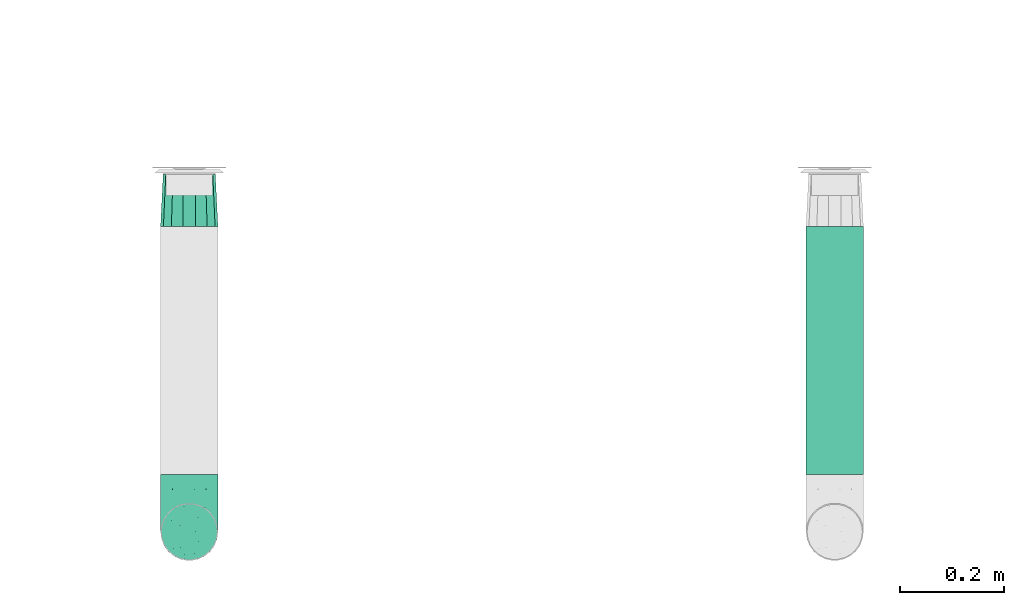
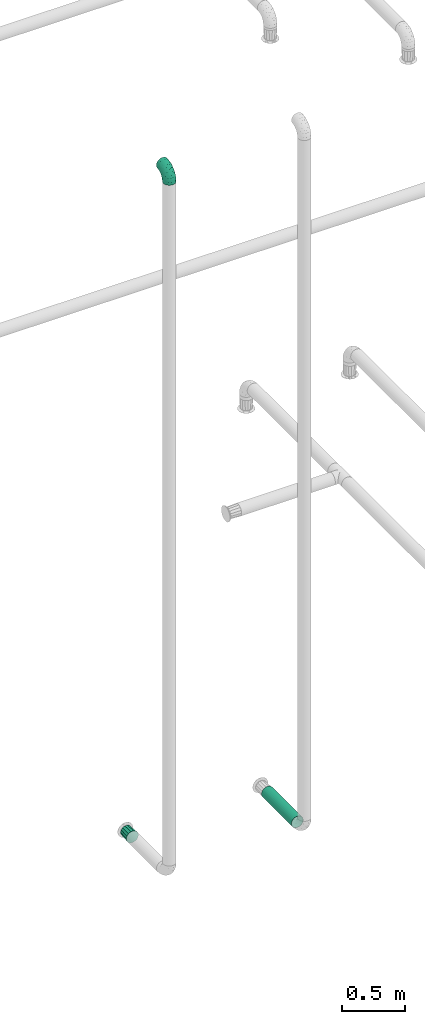
# One storey, part 34 of 123: 2 flow fittings, 1 flow segment.
"""IFC2X3 building model written with IfcOpenShell, lengths in millimetres."""

import ifcopenshell
import ifcopenshell.guid

model = None  # the IFC model being written
_history = None  # IfcOwnerHistory: only IFC2X3 demands one
_inside = {}  # id of a spatial element -> (the spatial element, [elements in it])
_under = {}  # id of a project, library or spatial element -> (it, [spatial elements below it])
_declared = {}  # id of a project -> (the project, [libraries it declares])
_typed = {}  # id of a type object -> (the type object, [elements of that type])
_made_of = {}  # id of a material, layer set ... -> (it, [elements and type objects made of it])


def new_model(schema):
    """Start an empty IFC model of exactly this schema.

    Asked for "IFC4X3", IfcOpenShell would pick the latest addendum, in which some entities
    have other attributes; the version numbers below select the first issue.
    IFC2X3 requires an IfcOwnerHistory on every rooted entity: one is made here for all.
    """
    global model, _history
    if schema == "IFC4X3":
        model = ifcopenshell.file(schema_version=(4, 3, 0, 0))
    else:
        model = ifcopenshell.file(schema=schema)
    _inside.clear()
    _under.clear()
    _declared.clear()
    _typed.clear()
    _made_of.clear()
    _history = None
    if model.schema == "IFC2X3":
        org = make("IfcOrganization", Name="unknown")
        user = make(
            "IfcPersonAndOrganization",
            ThePerson=make("IfcPerson", FamilyName="unknown"),
            TheOrganization=org,
        )
        app = make(
            "IfcApplication",
            ApplicationDeveloper=org,
            Version="unknown",
            ApplicationFullName="unknown",
            ApplicationIdentifier="unknown",
        )
        _history = make(
            "IfcOwnerHistory",
            OwningUser=user,
            OwningApplication=app,
            ChangeAction="ADDED",
            CreationDate=0,
        )
    return model


def make(cls, **values):
    """One entity of the class cls with the attributes given. An attribute that is None is left unset."""
    return model.create_entity(
        cls, **{name: value for name, value in values.items() if value is not None}
    )


def entity(cls, *values):
    """Any entity or typed value of the class cls, its attributes in the order of the schema. None: left unset."""
    e = model.create_entity(cls)
    for i, value in enumerate(values):
        if value is not None:
            e[i] = value
    return e


def rooted(cls, **values):
    """An entity with a GlobalId (a new one), such as an element, a storey or a relation."""
    return make(cls, GlobalId=ifcopenshell.guid.new(), OwnerHistory=_history, **values)


def si_unit(unit_type, name, prefix=None):
    """IfcSIUnit, for example si_unit("LENGTHUNIT", "METRE", prefix="MILLI")."""
    return make("IfcSIUnit", UnitType=unit_type, Prefix=prefix, Name=name)


def converted_unit(unit_type, name, factor, base, dimensions=None, offset=None):
    """IfcConversionBasedUnit, such as the inch: factor (a typed value) times the base unit."""
    return make(
        "IfcConversionBasedUnit"
        if offset is None
        else "IfcConversionBasedUnitWithOffset",
        ConversionOffset=offset,
        Dimensions=None
        if dimensions is None
        else entity("IfcDimensionalExponents", *dimensions),
        UnitType=unit_type,
        Name=name,
        ConversionFactor=make(
            "IfcMeasureWithUnit", ValueComponent=factor, UnitComponent=base
        ),
    )


def derived_unit(unit_type, elements):
    """IfcDerivedUnit: a product of units, each with its exponent."""
    return make(
        "IfcDerivedUnit",
        Elements=[
            make("IfcDerivedUnitElement", Unit=unit, Exponent=power)
            for unit, power in elements
        ],
        UnitType=unit_type,
    )


def assignment(units):
    """IfcUnitAssignment: the units of a project."""
    return None if units is None else make("IfcUnitAssignment", Units=units)


def point(xyz):
    """IfcCartesianPoint."""
    return None if xyz is None else make("IfcCartesianPoint", Coordinates=xyz)


def direction(xyz):
    """IfcDirection."""
    return None if xyz is None else make("IfcDirection", DirectionRatios=xyz)


def frame(location, z_axis=None, x_axis=None):
    """IfcAxis2Placement3D, a coordinate frame: its origin and axes. An axis left out is left unset."""
    return make(
        "IfcAxis2Placement3D",
        Location=point(location),
        Axis=direction(z_axis),
        RefDirection=direction(x_axis),
    )


def frame_2d(location, x_axis=None):
    """IfcAxis2Placement2D, a coordinate frame in the plane: its origin and x axis."""
    return make(
        "IfcAxis2Placement2D", Location=point(location), RefDirection=direction(x_axis)
    )


def origin_with_axes():
    """The frame at (0, 0, 0) with the z axis (0, 0, 1) and the x axis (1, 0, 0) written out."""
    return frame((0.0, 0.0, 0.0), z_axis=(0.0, 0.0, 1.0), x_axis=(1.0, 0.0, 0.0))


def origin_2d_with_axis():
    """The frame at (0, 0) in the plane with the x axis (1, 0) written out."""
    return frame_2d((0.0, 0.0), x_axis=(1.0, 0.0))


def place(relative_to, where):
    """IfcLocalPlacement: puts the frame where relative to a parent placement (None: the world)."""
    return make(
        "IfcLocalPlacement", PlacementRelTo=relative_to, RelativePlacement=where
    )


def context(
    kind, dimensions, precision=None, world=None, true_north=None, identifier=None
):
    """IfcGeometricRepresentationContext, for example the 3D "Model" context."""
    return make(
        "IfcGeometricRepresentationContext",
        ContextIdentifier=identifier,
        ContextType=kind,
        CoordinateSpaceDimension=dimensions,
        Precision=precision,
        WorldCoordinateSystem=world,
        TrueNorth=true_north,
    )


def subcontext(parent, identifier, kind, view, scale=None):
    """IfcGeometricRepresentationSubContext, for example "Body" below "Model"."""
    return make(
        "IfcGeometricRepresentationSubContext",
        ContextIdentifier=identifier,
        ContextType=kind,
        ParentContext=parent,
        TargetScale=scale,
        TargetView=view,
    )


def project(units=None, contexts=None):
    """IfcProject with its units and contexts."""
    return rooted(
        "IfcProject",
        Name="project",
        RepresentationContexts=contexts,
        UnitsInContext=assignment(units),
    )


def spatial(cls, under=None, at=None, **own):
    """A site, building, storey or space (cls), placed at a placement, below another one or the project."""
    s = rooted(cls, ObjectPlacement=at, **own)
    if under is not None:
        _under.setdefault(under.id(), (under, []))[1].append(s)
    return s


def profile(cls, at=None, kind="AREA", **sizes):
    """A parametric profile (cls). Its sizes go by their IFC names, for example OverallWidth=200.0."""
    return make(cls, ProfileType=kind, Position=at, **sizes)


def hollow_circle(**sizes):
    """IfcCircleHollowProfileDef."""
    return profile("IfcCircleHollowProfileDef", **sizes)


def extrude(swept, where, along, depth):
    """IfcExtrudedAreaSolid: the profile swept, set in the frame where, extruded along a direction by depth."""
    return make(
        "IfcExtrudedAreaSolid",
        SweptArea=swept,
        Position=where,
        ExtrudedDirection=direction(along),
        Depth=depth,
    )


def faces_of(points, faces, orient=None, outer=None):
    """IfcFace entities. A face is a list of loops; a loop is a list of indices into points, from 0.

    orient and outer hold one flag for each loop. By default every Orientation is true, the
    first loop of a face is its IfcFaceOuterBound and the others are IfcFaceBound.
    """
    made = []
    for i, loops in enumerate(faces):
        bounds = []
        for j, loop in enumerate(loops):
            is_outer = j == 0 if outer is None else outer[i][j]
            bounds.append(
                make(
                    "IfcFaceOuterBound" if is_outer else "IfcFaceBound",
                    Bound=make("IfcPolyLoop", Polygon=[points[k] for k in loop]),
                    Orientation=True if orient is None else orient[i][j],
                )
            )
        made.append(make("IfcFace", Bounds=bounds))
    return made


def open_shell(faces, orient=None, outer=None):
    """The faces of one IfcOpenShell. surface_model builds it on its shared points."""
    return ("IfcOpenShell", faces, orient, outer)


def surface_model(cls, points, shells):
    """IfcFaceBasedSurfaceModel or IfcShellBasedSurfaceModel (cls): surfaces that need not close."""
    shared = [point(p) for p in points]
    made = [make(c, CfsFaces=faces_of(shared, fs, o, b)) for c, fs, o, b in shells]
    if cls == "IfcFaceBasedSurfaceModel":
        return make(cls, FbsmFaces=made)
    return make(cls, SbsmBoundary=made)


def shape(context_of_items, identifier, shape_type, items):
    """IfcShapeRepresentation: the items that make up one representation, for example the "Body"."""
    return make(
        "IfcShapeRepresentation",
        ContextOfItems=context_of_items,
        RepresentationIdentifier=identifier,
        RepresentationType=shape_type,
        Items=items,
    )


def source(mapping_origin, context_of_items, identifier, shape_type, items):
    """IfcRepresentationMap: a shape defined once, which mapped items show again and again."""
    return make(
        "IfcRepresentationMap",
        MappingOrigin=mapping_origin,
        MappedRepresentation=shape(context_of_items, identifier, shape_type, items),
    )


def transform(
    local_origin,
    x_axis=None,
    y_axis=None,
    z_axis=None,
    scale=None,
    scale2=None,
    scale3=None,
    uniform=True,
):
    """IfcCartesianTransformationOperator3D, or its non-uniform kind. x_axis, y_axis, z_axis: its Axis1, 2, 3."""
    if uniform:
        return make(
            "IfcCartesianTransformationOperator3D",
            Axis1=direction(x_axis),
            Axis2=direction(y_axis),
            LocalOrigin=point(local_origin),
            Scale=scale,
            Axis3=direction(z_axis),
        )
    return make(
        "IfcCartesianTransformationOperator3DnonUniform",
        Axis1=direction(x_axis),
        Axis2=direction(y_axis),
        LocalOrigin=point(local_origin),
        Scale=scale,
        Axis3=direction(z_axis),
        Scale2=scale2,
        Scale3=scale3,
    )


def mapped(mapping_source, mapping_target):
    """IfcMappedItem: shows the shape of a source again, moved by a transform."""
    return make(
        "IfcMappedItem", MappingSource=mapping_source, MappingTarget=mapping_target
    )


def material(Name=None, Category=None):
    """IfcMaterial."""
    return make("IfcMaterial", Name=Name, Category=Category)


def layer(
    of_material, thickness, ventilated=None, Name=None, Category=None, Priority=None
):
    """IfcMaterialLayer: one layer of a wall or slab, of a material (None: an air gap)."""
    return make(
        "IfcMaterialLayer",
        Material=of_material,
        LayerThickness=thickness,
        IsVentilated=ventilated,
        Name=Name,
        Category=Category,
        Priority=Priority,
    )


def layer_set(layers, Name=None):
    """IfcMaterialLayerSet."""
    return make("IfcMaterialLayerSet", MaterialLayers=layers, LayerSetName=Name)


def layer_usage(for_layer_set, set_direction, sense, offset, extent=None):
    """IfcMaterialLayerSetUsage: how a layer set lies in its element."""
    return make(
        "IfcMaterialLayerSetUsage",
        ForLayerSet=for_layer_set,
        LayerSetDirection=set_direction,
        DirectionSense=sense,
        OffsetFromReferenceLine=offset,
        ReferenceExtent=extent,
    )


def made_of(thing, what):
    """Note that an element or type object is made of a material, layer set ...; save() writes the relation."""
    if what is not None:
        _made_of.setdefault(what.id(), (what, []))[1].append(thing)
    return thing


def type_object(cls, material=None, **own):
    """A type object (cls), such as IfcWallType, which elements share."""
    return made_of(rooted(cls, **own), material)


def element(
    cls,
    number,
    at=None,
    inside=None,
    cuts=None,
    type_object=None,
    material=None,
    context=None,
    identifier="Body",
    shape_type=None,
    held_by="IfcProductDefinitionShape",
    body=None,
    shapes=None,
    **own,
):
    """One element of the class cls, such as IfcWall. Its Tag is "e" and its number.

    at: its placement. inside: the storey or other place that contains it. cuts: it is an
    opening in that element (IfcRelVoidsElement). A single representation is given by context,
    identifier, shape_type and body (its items); several are given by shapes. held_by: the class
    of the entity that holds the representations. save() writes the other relations.
    """
    e = rooted(cls, Tag="e%d" % number, ObjectPlacement=at, **own)
    if body is not None:
        shapes = [shape(context, identifier, shape_type, body)]
    if shapes is not None:
        e.Representation = make(held_by, Representations=shapes)
    if inside is not None:
        _inside.setdefault(inside.id(), (inside, []))[1].append(e)
    if cuts is not None:
        rooted(
            "IfcRelVoidsElement", RelatingBuildingElement=cuts, RelatedOpeningElement=e
        )
    if type_object is not None:
        _typed.setdefault(type_object.id(), (type_object, []))[1].append(e)
    return made_of(e, material)


def aggregate(whole, parts):
    """IfcRelAggregates: a whole, such as a stair, and the parts it consists of."""
    return rooted("IfcRelAggregates", RelatingObject=whole, RelatedObjects=parts)


def save(model, path):
    """Write the relations noted so far, then the file.

    IfcRelAggregates (storeys below a building ...), IfcRelContainedInSpatialStructure (elements
    in a storey), IfcRelDefinesByType, IfcRelAssociatesMaterial and IfcRelDeclares: one each for
    every whole, place, type object, material and project.
    """
    for whole, parts in _under.values():
        aggregate(whole, parts)
    for where, things in _inside.values():
        rooted(
            "IfcRelContainedInSpatialStructure",
            RelatedElements=things,
            RelatingStructure=where,
        )
    for kind, things in _typed.values():
        rooted("IfcRelDefinesByType", RelatedObjects=things, RelatingType=kind)
    for what, things in _made_of.values():
        rooted("IfcRelAssociatesMaterial", RelatedObjects=things, RelatingMaterial=what)
    for by, libraries in _declared.values():
        rooted("IfcRelDeclares", RelatingContext=by, RelatedDefinitions=libraries)
    model.write(path)


model = new_model("IFC2X3")

# Units and contexts
model_context = context("Model", 3, precision=1e-05, world=origin_with_axes(), true_north=direction((0.0, 1.0)))
body_context = subcontext(model_context, "Body", "Model", "MODEL_VIEW")
ifc_project = project(units=[si_unit("AREAUNIT", "SQUARE_METRE"), si_unit("VOLUMEUNIT", "CUBIC_METRE", prefix="DECI"), si_unit("TIMEUNIT", "SECOND"), si_unit("THERMODYNAMICTEMPERATUREUNIT", "DEGREE_CELSIUS"), si_unit("PRESSUREUNIT", "PASCAL"), si_unit("MASSUNIT", "GRAM", prefix="KILO"), si_unit("LENGTHUNIT", "METRE", prefix="MILLI"), si_unit("POWERUNIT", "WATT"), si_unit("ELECTRICCURRENTUNIT", "AMPERE"), si_unit("ELECTRICVOLTAGEUNIT", "VOLT"), derived_unit("VOLUMETRICFLOWRATEUNIT", [(si_unit("VOLUMEUNIT", "CUBIC_METRE", prefix="DECI"), 1), (si_unit("TIMEUNIT", "SECOND"), -1)]), derived_unit("LINEARVELOCITYUNIT", [(si_unit("LENGTHUNIT", "METRE"), 1), (si_unit("TIMEUNIT", "SECOND"), -1)]), derived_unit("MASSDENSITYUNIT", [(si_unit("MASSUNIT", "GRAM", prefix="KILO"), 1), (si_unit("VOLUMEUNIT", "CUBIC_METRE"), -1)]), converted_unit("PLANEANGLEUNIT", "DEGREE", entity("IfcRatioMeasure", 0.01745), si_unit("PLANEANGLEUNIT", "RADIAN"), dimensions=[0, 0, 0, 0, 0, 0, 0])], contexts=[model_context])

# Site, building, storey
site_placement = place(None, origin_with_axes())
site = spatial("IfcSite", under=ifc_project, at=site_placement, CompositionType="ELEMENT")
building_placement = place(site_placement, origin_with_axes())
building = spatial("IfcBuilding", under=site, at=building_placement, Name="mc-building", CompositionType="ELEMENT")
storey_placement = place(building_placement, origin_with_axes())
storey = spatial("IfcBuildingStorey", under=building, at=storey_placement, Name="1. Korrus", CompositionType="ELEMENT", Elevation=0.0)

# Flow fittings
duct_fitting_type_1 = type_object("IfcDuctFittingType", PredefinedType="TRANSITION")
shared_shape_1 = source(origin_with_axes(), body_context, "Body", "SurfaceModel", [
    surface_model("IfcShellBasedSurfaceModel", [(100.0, -55.0, 0.0), (100.0, -12.23865, 53.62104), (100.0, -34.29194, 43.00073), (100.0, 49.55329, 23.86361), (100.0, 34.29194, 43.00073), (100.0, 49.55329, -23.86361), (0.0, -45.04844, -21.69419), (0.0, -50.0, 0.0), (0.0, -45.04844, 21.69419), (0.0, 31.17449, 39.09157), (0.0, 45.04844, 21.69419), (0.0, 50.0, 0.0), (98.0, 47.63139, 27.5), (98.0, 0.0, 55.0), (98.0, 38.89087, 38.89087), (98.0, -38.89087, 38.89087), (98.0, -47.63139, 27.5), (100.0, 12.23865, 53.62104), (100.0, -49.55329, 23.86361), (100.0, 55.0, 0.0), (100.0, 12.23865, -53.62104), (100.0, 34.29194, -43.00073), (100.0, -49.55329, -23.86361), (100.0, -34.29194, -43.00073), (100.0, -12.23865, -53.62104), (0.0, -31.17449, 39.09157), (0.0, -11.12605, 48.7464), (0.0, 11.12605, 48.7464), (0.0, -31.17449, -39.09157), (0.0, 11.12605, -48.7464), (0.0, -11.12605, -48.7464), (0.0, 45.04844, -21.69419), (0.0, 31.17449, -39.09157), (0.0, 47.52422, -10.84709), (0.0, 38.11147, -30.39288), (100.0, 41.92261, -33.43217), (100.0, -41.92261, -33.43217), (0.0, -38.11147, -30.39288), (100.0, 23.2653, -48.31088), (0.0, 21.15027, -43.91899), (100.0, 52.32388, -11.72483), (0.0, 0.0, -48.7464), (100.0, 0.0, -53.62104), (0.0, -21.15027, -43.91899), (100.0, -23.2653, -48.31088), (0.0, -47.52422, -10.84709), (100.0, -52.32388, -11.72483), (0.0, -47.52422, 10.84709), (0.0, -38.11147, 30.39288), (100.0, -41.92261, 33.43217), (100.0, 41.92261, 33.43217), (0.0, 38.11147, 30.39288), (100.0, -23.2653, 48.31088), (0.0, -21.15027, 43.91899), (100.0, -52.32388, 11.72483), (0.0, 0.0, 48.7464), (100.0, 0.0, 53.62104), (0.0, 21.15027, 43.91899), (100.0, 23.2653, 48.31088), (0.0, 47.52422, 10.84709), (100.0, 52.32388, 11.72483), (100.0, -14.23505, -53.12592), (100.0, 0.0, -55.0), (100.0, -27.5, -47.63139), (100.0, 27.5, -47.63139), (100.0, -38.89087, -38.89087), (100.0, -53.12592, -14.23505), (100.0, -47.63139, -27.5), (100.0, -47.63139, 27.5), (100.0, 14.23505, -53.12592), (100.0, 38.89087, -38.89087), (100.0, 47.63139, -27.5), (100.0, 47.63139, 27.5), (100.0, 53.12592, -14.23505), (100.0, -53.12592, 14.23505), (100.0, -38.89087, 38.89087), (100.0, -27.5, 47.63139), (100.0, 0.0, 55.0), (100.0, -14.23505, 53.12592), (100.0, 53.12592, 14.23505), (100.0, 38.89087, 38.89087), (100.0, 27.5, 47.63139), (100.0, 14.23505, 53.12592), (98.0, -27.5, 47.63139), (98.0, -14.23505, 53.12592), (98.0, -53.12592, -14.23505), (98.0, 14.23505, 53.12592), (98.0, 27.5, 47.63139), (98.0, 53.12592, 14.23505), (98.0, 55.0, 0.0), (98.0, -47.63139, -27.5), (98.0, -53.12592, 14.23505), (98.0, 27.5, -47.63139), (98.0, -27.5, -47.63139), (98.0, -38.89087, -38.89087), (98.0, 0.0, -55.0), (98.0, -14.23505, -53.12592), (98.0, 38.89087, -38.89087), (98.0, 47.63139, -27.5), (98.0, 53.12592, -14.23505), (98.0, 14.23505, -53.12592), (98.0, -55.0, 0.0), (0.0, 0.0, 50.0), (0.0, 35.35534, 35.35534), (0.0, -12.94095, 48.29629), (0.0, -25.0, 43.30127), (0.0, -35.35534, 35.35534), (0.0, -48.29629, 12.94095), (0.0, -43.30127, 25.0), (0.0, 25.0, 43.30127), (0.0, 12.94095, 48.29629), (0.0, 43.30127, 25.0), (0.0, 48.29629, 12.94095), (0.0, 25.0, -43.30127), (0.0, 48.29629, -12.94095), (0.0, -48.29629, -12.94095), (0.0, -43.30127, -25.0), (0.0, -12.94095, -48.29629), (0.0, -25.0, -43.30127), (0.0, -35.35534, -35.35534), (0.0, 43.30127, -25.0), (0.0, 35.35534, -35.35534), (0.0, 12.94095, -48.29629), (0.0, 0.0, -50.0), (2.0, -35.35534, -35.35534), (2.0, -25.0, -43.30127), (2.0, -12.94095, -48.29629), (2.0, -43.30127, -25.0), (2.0, 0.0, -50.0), (2.0, -48.29629, -12.94095), (2.0, -50.0, 0.0), (2.0, 12.94095, -48.29629), (2.0, 25.0, -43.30127), (2.0, 43.30127, -25.0), (2.0, 48.29629, -12.94095), (2.0, 35.35534, -35.35534), (2.0, -48.29629, 12.94095), (2.0, -35.35534, 35.35534), (2.0, -43.30127, 25.0), (2.0, 35.35534, 35.35534), (2.0, -12.94095, 48.29629), (2.0, -25.0, 43.30127), (2.0, 0.0, 50.0), (2.0, 43.30127, 25.0), (2.0, 48.29629, 12.94095), (2.0, 50.0, 0.0), (2.0, 25.0, 43.30127), (2.0, 12.94095, 48.29629)], [open_shell([[[0, 1, 2]], [[3, 4, 5]], [[6, 7, 8]], [[9, 10, 11]], [[12, 13, 14]], [[15, 13, 16]], [[0, 4, 17]], [[2, 18, 0]], [[1, 0, 17]], [[3, 5, 19]], [[20, 21, 5]], [[22, 20, 5]], [[22, 5, 0]], [[22, 23, 24]], [[22, 24, 20]], [[4, 0, 5]], [[8, 25, 6]], [[6, 25, 26]], [[6, 26, 27]], [[11, 27, 9]], [[28, 6, 29]], [[30, 28, 29]], [[31, 6, 11]], [[31, 32, 29]], [[31, 29, 6]], [[27, 11, 6]], [[31, 33, 5]], [[34, 35, 32]], [[36, 22, 6]], [[36, 37, 23]], [[38, 29, 39]], [[33, 40, 5]], [[33, 11, 40]], [[19, 40, 11]], [[32, 21, 39]], [[32, 35, 21]], [[34, 31, 35]], [[30, 41, 42]], [[28, 43, 44]], [[42, 41, 20]], [[7, 45, 46]], [[38, 39, 21]], [[46, 0, 7]], [[6, 37, 36]], [[38, 20, 29]], [[43, 30, 24]], [[42, 24, 30]], [[28, 23, 37]], [[6, 22, 45]], [[35, 31, 5]], [[44, 43, 24]], [[20, 41, 29]], [[46, 45, 22]], [[44, 23, 28]], [[8, 47, 18]], [[48, 49, 25]], [[50, 3, 10]], [[50, 51, 4]], [[52, 26, 53]], [[47, 54, 18]], [[47, 7, 54]], [[0, 54, 7]], [[25, 2, 53]], [[25, 49, 2]], [[48, 8, 49]], [[27, 55, 56]], [[9, 57, 58]], [[56, 55, 1]], [[11, 59, 60]], [[52, 53, 2]], [[60, 19, 11]], [[10, 51, 50]], [[52, 1, 26]], [[57, 27, 17]], [[56, 17, 27]], [[9, 4, 51]], [[10, 3, 59]], [[49, 8, 18]], [[58, 57, 17]], [[1, 55, 26]], [[60, 59, 3]], [[58, 4, 9]], [[61, 62, 63]], [[63, 64, 65]], [[66, 67, 68]], [[65, 64, 67]], [[67, 64, 68]], [[69, 64, 62]], [[64, 63, 62]], [[70, 71, 64]], [[72, 64, 71]], [[71, 73, 19]], [[74, 0, 66]], [[72, 68, 64]], [[75, 68, 76]], [[77, 78, 76]], [[72, 76, 68]], [[76, 72, 77]], [[79, 72, 19]], [[19, 72, 71]], [[80, 81, 77]], [[77, 72, 80]], [[82, 77, 81]], [[74, 66, 68]], [[83, 84, 13]], [[15, 83, 13]], [[12, 16, 13]], [[16, 12, 85]], [[86, 87, 13]], [[87, 14, 13]], [[88, 89, 12]], [[89, 90, 12]], [[91, 16, 85]], [[90, 85, 12]], [[89, 92, 90]], [[93, 94, 95]], [[95, 94, 90]], [[96, 93, 95]], [[97, 92, 98]], [[98, 89, 99]], [[100, 95, 92]], [[92, 89, 98]], [[90, 92, 95]], [[101, 91, 85]], [[89, 73, 99]], [[99, 71, 98]], [[92, 97, 64]], [[70, 97, 98]], [[100, 92, 69]], [[73, 71, 99]], [[89, 19, 73]], [[92, 64, 69]], [[64, 97, 70]], [[98, 71, 70]], [[100, 69, 62]], [[62, 95, 100]], [[95, 61, 96]], [[96, 63, 93]], [[90, 94, 67]], [[65, 94, 93]], [[85, 90, 66]], [[63, 65, 93]], [[96, 61, 63]], [[85, 66, 0]], [[66, 90, 67]], [[94, 65, 67]], [[85, 0, 101]], [[62, 61, 95]], [[101, 74, 91]], [[91, 68, 16]], [[83, 15, 76]], [[75, 15, 16]], [[84, 83, 78]], [[74, 68, 91]], [[101, 0, 74]], [[83, 76, 78]], [[76, 15, 75]], [[16, 68, 75]], [[84, 78, 77]], [[77, 13, 84]], [[13, 82, 86]], [[86, 81, 87]], [[12, 14, 72]], [[80, 14, 87]], [[88, 12, 79]], [[81, 80, 87]], [[86, 82, 81]], [[88, 79, 19]], [[79, 12, 72]], [[14, 80, 72]], [[88, 19, 89]], [[77, 82, 13]], [[102, 103, 104]], [[105, 104, 106]], [[107, 108, 106]], [[103, 106, 104]], [[106, 103, 107]], [[109, 103, 110]], [[103, 102, 110]], [[111, 112, 103]], [[113, 103, 112]], [[112, 11, 114]], [[107, 103, 113]], [[113, 115, 107]], [[116, 115, 117]], [[117, 118, 119]], [[116, 117, 119]], [[117, 115, 113]], [[120, 121, 114]], [[113, 114, 121]], [[113, 122, 117]], [[113, 112, 114]], [[117, 122, 123]], [[7, 107, 115]], [[124, 125, 126]], [[127, 124, 126]], [[128, 129, 126]], [[127, 126, 129]], [[130, 129, 128]], [[131, 132, 128]], [[132, 130, 128]], [[133, 134, 135]], [[132, 135, 134]], [[132, 134, 130]], [[134, 136, 130]], [[137, 138, 136]], [[137, 136, 139]], [[140, 137, 139]], [[141, 137, 140]], [[142, 140, 139]], [[143, 139, 144]], [[144, 134, 145]], [[146, 147, 139]], [[139, 136, 144]], [[139, 147, 142]], [[136, 134, 144]], [[11, 134, 114]], [[114, 133, 120]], [[113, 121, 132]], [[135, 121, 120]], [[122, 113, 131]], [[134, 133, 114]], [[11, 145, 134]], [[113, 132, 131]], [[132, 121, 135]], [[120, 133, 135]], [[122, 131, 128]], [[128, 123, 122]], [[123, 126, 117]], [[117, 125, 118]], [[116, 119, 127]], [[124, 119, 118]], [[115, 116, 129]], [[125, 124, 118]], [[117, 126, 125]], [[115, 129, 130]], [[129, 116, 127]], [[119, 124, 127]], [[115, 130, 7]], [[128, 126, 123]], [[7, 136, 107]], [[107, 138, 108]], [[105, 106, 141]], [[137, 106, 108]], [[104, 105, 140]], [[136, 138, 107]], [[7, 130, 136]], [[105, 141, 140]], [[141, 106, 137]], [[108, 138, 137]], [[104, 140, 142]], [[142, 102, 104]], [[102, 147, 110]], [[110, 146, 109]], [[111, 103, 143]], [[139, 103, 109]], [[112, 111, 144]], [[146, 139, 109]], [[110, 147, 146]], [[112, 144, 145]], [[144, 111, 143]], [[103, 139, 143]], [[112, 145, 11]], [[142, 147, 102]]])]),
])
flow_fitting_1_placement = place(storey_placement, frame((11692.81055, -2.39828, 2300.0), z_axis=(0.0, 0.0, 1.0), x_axis=(0.0, -1.0, 0.0)))
element("IfcFlowFitting", 1, at=flow_fitting_1_placement, inside=storey, type_object=duct_fitting_type_1, context=body_context, shape_type="MappedRepresentation", body=[
    mapped(shared_shape_1, transform((0.0, 0.0, 0.0), scale=1.0)),
])
duct_fitting_type_2 = type_object("IfcDuctFittingType", Name="BU", PredefinedType="BEND")
shared_shape_2 = source(origin_with_axes(), body_context, "Body", "SurfaceModel", [
    surface_model("IfcShellBasedSurfaceModel", [(-110.0, -38.89087, -38.89087), (-110.0, -55.0, 0.0), (-110.0, -27.5, -47.63139), (-110.0, -53.12592, -14.23505), (-110.0, -47.63139, -27.5), (-110.0, 47.63139, -27.5), (-110.0, 53.12592, 14.23505), (-110.0, 53.12592, -14.23505), (-110.0, -14.23505, -53.12592), (-110.0, 0.0, -55.0), (-110.0, 38.89087, -38.89087), (-110.0, 27.5, -47.63139), (-110.0, 14.23505, -53.12592), (-110.0, 55.0, 0.0), (-110.0, -53.12592, 14.23505), (-110.0, -47.63139, 27.5), (-110.0, -38.89087, 38.89087), (-110.0, 0.0, 55.0), (-110.0, -27.5, 47.63139), (-110.0, -14.23505, 53.12592), (-110.0, 38.89087, 38.89087), (-110.0, 47.63139, 27.5), (-110.0, 27.5, 47.63139), (-110.0, 14.23505, 53.12592), (0.0, -110.0, -55.0), (14.23505, -110.0, -53.12592), (-14.23505, -110.0, -53.12592), (-53.12592, -110.0, 14.23505), (-27.5, -110.0, -47.63139), (-47.63139, -110.0, -27.5), (-38.89087, -110.0, -38.89087), (55.0, -110.0, 0.0), (53.12592, -110.0, 14.23505), (38.89087, -110.0, -38.89087), (27.5, -110.0, -47.63139), (53.12592, -110.0, -14.23505), (47.63139, -110.0, -27.5), (-53.12592, -110.0, -14.23505), (-47.63139, -110.0, 27.5), (-38.89087, -110.0, 38.89087), (14.23505, -110.0, 53.12592), (-27.5, -110.0, 47.63139), (-14.23505, -110.0, 53.12592), (47.63139, -110.0, 27.5), (38.89087, -110.0, 38.89087), (27.5, -110.0, 47.63139), (0.0, -110.0, 55.0), (-55.0, -110.0, 0.0), (-60.44912, -32.56953, 51.94617), (-76.6405, -38.18013, 45.55988), (-64.21732, -48.68956, 43.63444), (-90.15553, -11.94394, 54.09138), (-76.00813, -5.38378, 55.0), (-70.18771, -18.55163, 54.03432), (-78.5998, -26.77405, 50.81338), (-93.27622, -45.77614, 33.48188), (-75.55424, -54.2118, 32.41257), (-96.12334, -22.13664, 50.81337), (-32.04182, -59.64019, 52.24446), (-18.36258, -70.48427, 54.04484), (-21.00813, -45.34362, 55.0), (-63.60674, -66.07878, 29.97482), (-74.66383, -63.08407, 19.92123), (-63.88653, -74.77858, 17.99134), (-93.11138, -56.59448, 10.50359), (-99.597, -52.72185, 18.52927), (-98.21577, -57.34403, 0.0), (-53.42855, -92.60092, 21.04759), (-88.54852, -54.8376, 21.04759), (-5.38378, -76.00813, 55.0), (-11.86161, -90.23965, 54.10313), (-56.64619, -93.12774, 10.22088), (-57.34403, -98.21577, 0.0), (-44.60838, -44.60838, 52.13415), (-45.34362, -21.00813, 55.0), (-92.68484, -35.46673, 43.63443), (-22.25266, -95.40765, 50.81337), (-27.23711, -77.39884, 50.81337), (-43.70931, -69.58671, 44.47149), (-35.97783, -90.61597, 43.63443), (-58.67786, -84.31125, 16.04456), (-57.2828, -79.3123, 24.9774), (-82.93277, -60.36161, 12.91784), (-49.88337, -54.51816, 47.224), (-74.57753, -66.83759, 9.55742), (-45.35812, -94.97281, 33.48188), (-59.18663, -88.95241, 0.0), (-51.517, -78.6292, 33.48188), (-65.14788, -80.03077, 0.0), (-56.45322, -62.06476, 39.63545), (-88.95241, -59.18663, 0.0), (-80.03077, -65.14788, 0.0), (-71.10913, -71.10913, 0.0), (-94.9309, -45.36788, -33.48188), (-93.11358, -56.60141, -10.46614), (-99.64997, -52.79499, -18.30015), (-79.99933, -46.56772, -37.92748), (-90.20425, -36.08686, -43.63443), (-45.34362, -21.00813, -55.0), (-72.75364, -19.68651, -53.60527), (-76.00813, -5.38378, -55.0), (-21.00813, -45.34362, -55.0), (-5.38378, -76.00813, -55.0), (-21.91957, -65.12078, -53.85897), (-35.41876, -92.89265, -43.63443), (-91.10309, -11.02766, -54.21832), (-45.77614, -93.27622, -33.48188), (-90.50474, -23.21022, -50.81337), (-70.92854, -33.31794, -49.51754), (-78.52933, -63.35627, -11.73997), (-24.91508, -84.05606, -50.81337), (-88.78941, -54.74452, -21.04759), (-63.49062, -67.59111, -28.46929), (-73.36422, -62.46673, -22.94182), (-69.59921, -57.34866, -33.48187), (-56.59448, -93.11138, -10.50359), (-54.10679, -75.85581, -32.31867), (-54.8376, -88.54852, -21.04759), (-57.75956, -31.09612, -52.80882), (-52.72185, -99.597, -18.52927), (-12.62913, -89.46304, -53.99097), (-34.46825, -66.46123, -50.04329), (-43.9837, -43.9837, -52.42279), (-65.78527, -72.58348, -17.68796), (-57.47001, -51.99467, -44.91465), (-70.34468, -43.65295, -44.21951), (-60.72547, -82.29174, -12.88567), (-42.34915, -74.24548, -43.63444), (-57.25194, -63.5016, -38.08211), (-80.95344, -53.56991, -29.32027), (-52.32891, -4.55257, -54.0482), (14.95561, -36.05775, -42.26543), (14.88266, -20.92917, -33.7947), (32.52942, -47.13398, -30.48571), (19.3559, -65.35825, -48.00507), (30.24048, -70.09027, -41.7461), (-28.49299, 30.5778, -16.4009), (-47.13398, 32.52942, -30.48571), (-70.35075, 46.44478, -19.5952), (-22.4954, -22.4954, -53.25347), (-4.55257, -52.32891, -54.0482), (-75.47368, 11.22546, -52.60718), (-81.32209, 51.5606, -9.98467), (-70.09027, 30.24048, -41.7461), (-80.81763, 41.84862, -32.14655), (-9.15831, 10.852, -27.8997), (-36.05774, 14.95561, -42.26543), (-65.35825, 19.3559, -48.00507), (3.94376, -43.9333, -50.53315), (11.22546, -75.47368, -52.60718), (-43.9333, 3.94376, -50.53315), (-13.39742, -13.39743, -48.13058), (50.20582, -74.51695, -9.9731), (41.8609, -47.82256, -9.92641), (49.37776, -67.29486, 0.0), (18.93131, -11.7156, -17.56239), (-1.23348, 12.25375, -12.18106), (-27.5, 32.89419, 0.0), (41.84862, -80.81763, -32.14655), (46.44478, -70.35075, -19.5952), (35.70604, -41.31408, -20.38235), (6.67262, 6.67262, 0.0), (32.89419, -27.5, 0.0), (-50.36265, 42.95545, -9.51562), (-67.29486, 49.37776, 0.0), (-5.47251, -5.47251, -39.92906), (-70.35075, 46.44478, 19.5952), (-74.51695, 50.20582, 9.9731), (-47.13398, 32.52942, 30.48571), (-41.31407, 35.70604, 20.38235), (-80.81763, 41.84862, 32.14655), (11.22546, -75.47368, 52.60718), (-4.55257, -52.32891, 54.0482), (-36.05774, 14.95561, 42.26543), (-65.35825, 19.3559, 48.00507), (-43.9333, 3.94376, 50.53315), (-70.09027, 30.24048, 41.7461), (-11.7156, 18.93131, 17.56239), (12.25375, -1.23348, 12.18106), (30.5778, -28.49299, 16.4009), (42.95545, -50.36265, 9.51562), (51.5606, -81.32209, 9.98467), (-52.32891, -4.55257, 54.0482), (-75.47368, 11.22546, 52.60718), (-13.39742, -13.39743, 48.13058), (-22.4954, -22.4954, 53.25347), (3.94376, -43.9333, 50.53315), (-20.92916, 14.88266, 33.79469), (10.852, -9.15831, 27.8997), (-47.82256, 41.8609, 9.92641), (32.52942, -47.13398, 30.48571), (46.44478, -70.35075, 19.5952), (41.84862, -80.81763, 32.14655), (14.95561, -36.05775, 42.26543), (19.3559, -65.35825, 48.00507), (30.24048, -70.09027, 41.7461), (-5.47251, -5.47251, 39.92906)], [open_shell([[[0, 1, 2]], [[3, 1, 4]], [[5, 6, 7]], [[8, 1, 9]], [[2, 1, 8]], [[4, 1, 0]], [[10, 9, 6]], [[9, 10, 11]], [[11, 12, 9]], [[6, 5, 10]], [[7, 6, 13]], [[14, 15, 9]], [[9, 15, 16]], [[17, 16, 18]], [[9, 16, 17]], [[19, 17, 18]], [[9, 20, 21]], [[6, 9, 21]], [[9, 22, 20]], [[23, 22, 9]], [[17, 23, 9]], [[9, 1, 14]], [[24, 25, 26]], [[26, 27, 28]], [[29, 30, 27]], [[28, 27, 30]], [[26, 31, 32]], [[33, 31, 34]], [[25, 34, 31]], [[35, 31, 36]], [[33, 36, 31]], [[31, 26, 25]], [[29, 27, 37]], [[38, 27, 26]], [[39, 38, 26]], [[40, 41, 26]], [[41, 39, 26]], [[40, 42, 41]], [[43, 44, 26]], [[43, 26, 32]], [[44, 45, 26]], [[26, 45, 40]], [[40, 46, 42]], [[47, 37, 27]], [[48, 49, 50]], [[51, 52, 17]], [[48, 53, 54]], [[49, 55, 56]], [[16, 15, 55]], [[18, 57, 19]], [[58, 59, 60]], [[61, 62, 63]], [[64, 65, 14]], [[53, 51, 54]], [[66, 64, 14]], [[27, 38, 67]], [[65, 68, 55]], [[68, 65, 64]], [[69, 59, 70]], [[71, 72, 27]], [[73, 60, 74]], [[55, 49, 75]], [[42, 70, 76]], [[51, 57, 54]], [[77, 78, 79]], [[42, 76, 41]], [[46, 70, 42]], [[55, 68, 56]], [[75, 18, 16]], [[77, 79, 76]], [[80, 67, 81]], [[68, 82, 62]], [[83, 78, 58]], [[82, 84, 62]], [[39, 79, 85]], [[71, 67, 80]], [[72, 71, 86]], [[67, 85, 87]], [[88, 80, 63]], [[39, 41, 79]], [[87, 79, 78]], [[55, 75, 16]], [[50, 89, 83]], [[38, 39, 85]], [[56, 68, 62]], [[61, 87, 89]], [[48, 50, 83]], [[18, 75, 57]], [[54, 75, 49]], [[38, 85, 67]], [[85, 79, 87]], [[56, 62, 61]], [[50, 56, 89]], [[87, 61, 81]], [[90, 64, 66]], [[14, 1, 66]], [[91, 92, 84]], [[82, 90, 91]], [[90, 82, 64]], [[62, 84, 63]], [[84, 82, 91]], [[64, 82, 68]], [[65, 15, 14]], [[15, 65, 55]], [[72, 47, 27]], [[86, 71, 80]], [[67, 71, 27]], [[88, 63, 92]], [[63, 80, 81]], [[63, 81, 61]], [[87, 81, 67]], [[41, 76, 79]], [[70, 59, 77]], [[76, 70, 77]], [[69, 70, 46]], [[77, 59, 58]], [[59, 69, 60]], [[77, 58, 78]], [[73, 58, 60]], [[19, 57, 51]], [[54, 57, 75]], [[19, 51, 17]], [[53, 52, 51]], [[53, 74, 52]], [[73, 74, 48]], [[53, 48, 74]], [[83, 73, 48]], [[73, 83, 58]], [[78, 83, 89]], [[78, 89, 87]], [[61, 89, 56]], [[54, 49, 48]], [[50, 49, 56]], [[88, 86, 80]], [[63, 84, 92]], [[93, 4, 0]], [[66, 94, 90]], [[95, 94, 3]], [[96, 93, 97]], [[98, 99, 100]], [[0, 2, 97]], [[101, 102, 103]], [[104, 28, 30]], [[9, 105, 8]], [[30, 106, 104]], [[107, 105, 99]], [[97, 107, 108]], [[94, 109, 90]], [[2, 8, 107]], [[94, 66, 3]], [[110, 26, 28]], [[94, 111, 109]], [[112, 113, 114]], [[72, 115, 37]], [[116, 106, 117]], [[98, 118, 99]], [[119, 115, 117]], [[115, 119, 37]], [[110, 120, 26]], [[103, 110, 121]], [[117, 106, 119]], [[120, 110, 103]], [[98, 101, 122]], [[117, 123, 116]], [[108, 124, 125]], [[126, 117, 115]], [[30, 29, 106]], [[120, 102, 24]], [[110, 104, 127]], [[97, 125, 96]], [[118, 122, 124]], [[124, 127, 128]], [[93, 0, 97]], [[86, 126, 115]], [[127, 106, 116]], [[129, 113, 111]], [[4, 93, 95]], [[114, 129, 96]], [[28, 104, 110]], [[127, 104, 106]], [[2, 107, 97]], [[108, 107, 99]], [[118, 108, 99]], [[100, 99, 105]], [[128, 112, 114]], [[127, 124, 121]], [[66, 1, 3]], [[91, 90, 109]], [[95, 111, 94]], [[109, 123, 92]], [[114, 113, 129]], [[111, 95, 93]], [[95, 3, 4]], [[86, 115, 72]], [[37, 47, 72]], [[88, 92, 123]], [[123, 117, 126]], [[126, 88, 123]], [[88, 126, 86]], [[119, 29, 37]], [[29, 119, 106]], [[111, 93, 129]], [[124, 114, 125]], [[100, 105, 9]], [[8, 105, 107]], [[108, 118, 124]], [[122, 118, 98]], [[96, 129, 93]], [[109, 111, 113]], [[113, 123, 109]], [[116, 123, 112]], [[113, 112, 123]], [[116, 112, 128]], [[116, 128, 127]], [[124, 128, 114]], [[103, 122, 101]], [[127, 121, 110]], [[121, 122, 103]], [[122, 121, 124]], [[26, 120, 24]], [[102, 120, 103]], [[108, 125, 97]], [[109, 92, 91]], [[96, 125, 114]], [[100, 130, 98]], [[131, 132, 133]], [[134, 135, 34]], [[136, 137, 138]], [[101, 139, 140]], [[9, 141, 100]], [[138, 7, 142]], [[137, 143, 144]], [[142, 7, 13]], [[145, 146, 137]], [[146, 147, 143]], [[5, 138, 144]], [[7, 138, 5]], [[5, 144, 10]], [[140, 148, 149]], [[143, 11, 10]], [[147, 12, 11]], [[100, 141, 130]], [[98, 139, 101]], [[148, 134, 149]], [[139, 150, 151]], [[152, 153, 154]], [[150, 139, 130]], [[25, 24, 149]], [[141, 12, 147]], [[132, 145, 155]], [[156, 136, 157]], [[158, 33, 135]], [[148, 139, 151]], [[36, 33, 158]], [[34, 135, 33]], [[159, 160, 153]], [[160, 159, 133]], [[137, 146, 143]], [[152, 154, 31]], [[137, 136, 145]], [[161, 162, 155]], [[133, 159, 158]], [[134, 148, 131]], [[163, 164, 157]], [[163, 142, 164]], [[102, 101, 140]], [[162, 154, 153]], [[159, 35, 36]], [[155, 156, 161]], [[131, 165, 132]], [[155, 145, 156]], [[98, 130, 139]], [[150, 130, 141]], [[147, 150, 141]], [[9, 12, 141]], [[149, 24, 102]], [[148, 140, 139]], [[140, 149, 102]], [[34, 25, 134]], [[146, 151, 150]], [[143, 147, 11]], [[147, 146, 150]], [[145, 165, 146]], [[25, 149, 134]], [[135, 134, 131]], [[135, 131, 133]], [[151, 165, 131]], [[148, 151, 131]], [[165, 151, 146]], [[160, 133, 132]], [[132, 165, 145]], [[36, 158, 159]], [[133, 158, 135]], [[10, 144, 143]], [[137, 144, 138]], [[162, 153, 155]], [[159, 153, 152]], [[160, 155, 153]], [[155, 160, 132]], [[152, 35, 159]], [[35, 152, 31]], [[136, 138, 163]], [[164, 142, 13]], [[142, 163, 138]], [[136, 163, 157]], [[161, 156, 157]], [[136, 156, 145]], [[166, 6, 21]], [[167, 164, 13]], [[166, 168, 169]], [[170, 168, 166]], [[69, 171, 172]], [[173, 174, 175]], [[174, 176, 22]], [[161, 157, 177]], [[170, 20, 176]], [[21, 20, 170]], [[178, 179, 162]], [[180, 181, 154]], [[182, 175, 183]], [[183, 23, 17]], [[184, 185, 186]], [[74, 185, 182]], [[52, 74, 182]], [[187, 188, 177]], [[166, 169, 189]], [[190, 179, 188]], [[22, 176, 20]], [[180, 154, 162]], [[32, 191, 43]], [[192, 44, 43]], [[43, 191, 192]], [[32, 31, 181]], [[193, 194, 195]], [[194, 40, 45]], [[190, 193, 195]], [[45, 44, 195]], [[69, 46, 171]], [[74, 60, 185]], [[157, 164, 189]], [[167, 189, 164]], [[172, 60, 69]], [[185, 172, 186]], [[173, 187, 168]], [[191, 32, 181]], [[190, 195, 192]], [[179, 190, 191]], [[175, 174, 183]], [[171, 40, 194]], [[188, 193, 190]], [[175, 185, 184]], [[177, 178, 161]], [[173, 196, 187]], [[177, 188, 178]], [[60, 172, 185]], [[186, 172, 171]], [[194, 186, 171]], [[46, 40, 171]], [[183, 17, 52]], [[175, 182, 185]], [[182, 183, 52]], [[22, 23, 174]], [[193, 184, 186]], [[195, 194, 45]], [[194, 193, 186]], [[188, 196, 193]], [[23, 183, 174]], [[176, 174, 173]], [[176, 173, 168]], [[184, 196, 173]], [[175, 184, 173]], [[196, 184, 193]], [[169, 168, 187]], [[187, 196, 188]], [[21, 170, 166]], [[168, 170, 176]], [[44, 192, 195]], [[190, 192, 191]], [[157, 189, 177]], [[166, 189, 167]], [[169, 177, 189]], [[177, 169, 187]], [[167, 6, 166]], [[6, 167, 13]], [[179, 191, 180]], [[154, 181, 31]], [[181, 180, 191]], [[179, 180, 162]], [[161, 178, 162]], [[179, 178, 188]]])]),
])
flow_fitting_2_placement = place(storey_placement, frame((11692.81055, -687.64676, 9115.0), z_axis=(1.0, 0.0, 0.0), x_axis=(0.0, 0.0, 1.0)))
element("IfcFlowFitting", 2, at=flow_fitting_2_placement, inside=storey, type_object=duct_fitting_type_2, Name="BU", context=body_context, shape_type="MappedRepresentation", body=[
    mapped(shared_shape_2, transform((0.0, 0.0, 0.0), scale=1.0)),
])

# Flow segment
ifc_material = material(Name="FZ1")
ifc_layer = layer(ifc_material, 0.0)
ifc_layer_set = layer_set([ifc_layer], Name="FZ1")
ifc_layer_usage = layer_usage(ifc_layer_set, "AXIS1", "POSITIVE", 0.0)
duct_segment_type = type_object("IfcDuctSegmentType", PredefinedType="RIGIDSEGMENT")
shared_shape_3 = source(origin_with_axes(), body_context, "Body", "SweptSolid", [
    extrude(hollow_circle(Radius=55.0, WallThickness=2.0, at=origin_2d_with_axis()), frame((0.0, 0.0, 0.0), z_axis=(1.0, 0.0, 0.0), x_axis=(0.0, 1.0, 0.0)), (0.0, 0.0, 1.0), 475.2),
])
flow_segment_placement = place(storey_placement, frame((12930.40917, -102.39828, 2300.0), z_axis=(0.0, 0.0, 1.0), x_axis=(0.0, -1.0, 0.0)))
element("IfcFlowSegment", 3, at=flow_segment_placement, inside=storey, type_object=duct_segment_type, material=ifc_layer_usage, context=body_context, shape_type="MappedRepresentation", body=[
    mapped(shared_shape_3, transform((0.0, 0.0, 0.0), scale=1.0)),
])

save(model, "model.ifc")
